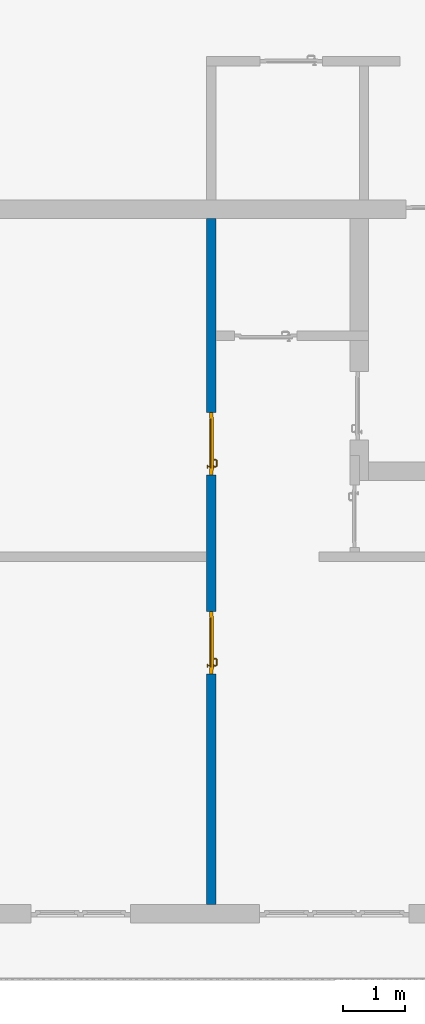
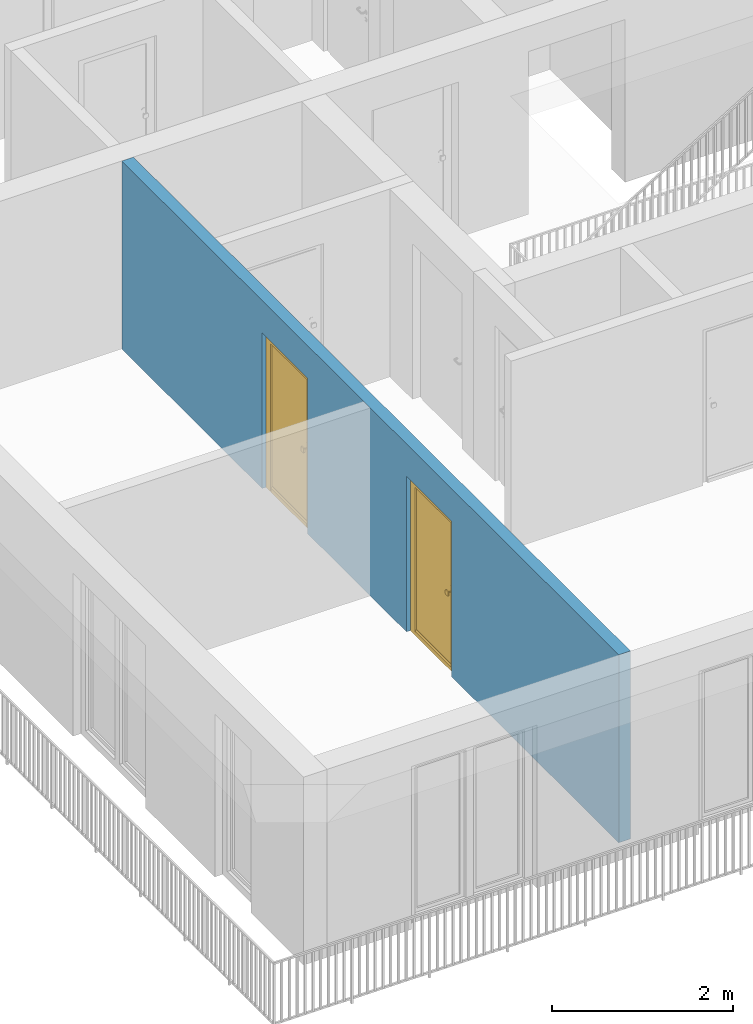
# One storey, part 8 of 54: 2 doors, 1 wall, 2 openings.
"""IFC4 building model written with IfcOpenShell, lengths in metres."""

import ifcopenshell
import ifcopenshell.guid

model = None  # the IFC model being written
_history = None  # IfcOwnerHistory: only IFC2X3 demands one
_inside = {}  # id of a spatial element -> (the spatial element, [elements in it])
_under = {}  # id of a project, library or spatial element -> (it, [spatial elements below it])
_declared = {}  # id of a project -> (the project, [libraries it declares])
_typed = {}  # id of a type object -> (the type object, [elements of that type])
_made_of = {}  # id of a material, layer set ... -> (it, [elements and type objects made of it])


def new_model(schema):
    """Start an empty IFC model of exactly this schema.

    Asked for "IFC4X3", IfcOpenShell would pick the latest addendum, in which some entities
    have other attributes; the version numbers below select the first issue.
    IFC2X3 requires an IfcOwnerHistory on every rooted entity: one is made here for all.
    """
    global model, _history
    if schema == "IFC4X3":
        model = ifcopenshell.file(schema_version=(4, 3, 0, 0))
    else:
        model = ifcopenshell.file(schema=schema)
    _inside.clear()
    _under.clear()
    _declared.clear()
    _typed.clear()
    _made_of.clear()
    _history = None
    if model.schema == "IFC2X3":
        org = make("IfcOrganization", Name="unknown")
        user = make(
            "IfcPersonAndOrganization",
            ThePerson=make("IfcPerson", FamilyName="unknown"),
            TheOrganization=org,
        )
        app = make(
            "IfcApplication",
            ApplicationDeveloper=org,
            Version="unknown",
            ApplicationFullName="unknown",
            ApplicationIdentifier="unknown",
        )
        _history = make(
            "IfcOwnerHistory",
            OwningUser=user,
            OwningApplication=app,
            ChangeAction="ADDED",
            CreationDate=0,
        )
    return model


def make(cls, **values):
    """One entity of the class cls with the attributes given. An attribute that is None is left unset."""
    return model.create_entity(
        cls, **{name: value for name, value in values.items() if value is not None}
    )


def entity(cls, *values):
    """Any entity or typed value of the class cls, its attributes in the order of the schema. None: left unset."""
    e = model.create_entity(cls)
    for i, value in enumerate(values):
        if value is not None:
            e[i] = value
    return e


def rooted(cls, **values):
    """An entity with a GlobalId (a new one), such as an element, a storey or a relation."""
    return make(cls, GlobalId=ifcopenshell.guid.new(), OwnerHistory=_history, **values)


def si_unit(unit_type, name, prefix=None):
    """IfcSIUnit, for example si_unit("LENGTHUNIT", "METRE", prefix="MILLI")."""
    return make("IfcSIUnit", UnitType=unit_type, Prefix=prefix, Name=name)


def converted_unit(unit_type, name, factor, base, dimensions=None, offset=None):
    """IfcConversionBasedUnit, such as the inch: factor (a typed value) times the base unit."""
    return make(
        "IfcConversionBasedUnit"
        if offset is None
        else "IfcConversionBasedUnitWithOffset",
        ConversionOffset=offset,
        Dimensions=None
        if dimensions is None
        else entity("IfcDimensionalExponents", *dimensions),
        UnitType=unit_type,
        Name=name,
        ConversionFactor=make(
            "IfcMeasureWithUnit", ValueComponent=factor, UnitComponent=base
        ),
    )


def derived_unit(unit_type, elements):
    """IfcDerivedUnit: a product of units, each with its exponent."""
    return make(
        "IfcDerivedUnit",
        Elements=[
            make("IfcDerivedUnitElement", Unit=unit, Exponent=power)
            for unit, power in elements
        ],
        UnitType=unit_type,
    )


def assignment(units):
    """IfcUnitAssignment: the units of a project."""
    return None if units is None else make("IfcUnitAssignment", Units=units)


def point(xyz):
    """IfcCartesianPoint."""
    return None if xyz is None else make("IfcCartesianPoint", Coordinates=xyz)


def direction(xyz):
    """IfcDirection."""
    return None if xyz is None else make("IfcDirection", DirectionRatios=xyz)


def frame(location, z_axis=None, x_axis=None):
    """IfcAxis2Placement3D, a coordinate frame: its origin and axes. An axis left out is left unset."""
    return make(
        "IfcAxis2Placement3D",
        Location=point(location),
        Axis=direction(z_axis),
        RefDirection=direction(x_axis),
    )


def origin_with_axes():
    """The frame at (0, 0, 0) with the z axis (0, 0, 1) and the x axis (1, 0, 0) written out."""
    return frame((0.0, 0.0, 0.0), z_axis=(0.0, 0.0, 1.0), x_axis=(1.0, 0.0, 0.0))


def place(relative_to, where):
    """IfcLocalPlacement: puts the frame where relative to a parent placement (None: the world)."""
    return make(
        "IfcLocalPlacement", PlacementRelTo=relative_to, RelativePlacement=where
    )


def context(
    kind, dimensions, precision=None, world=None, true_north=None, identifier=None
):
    """IfcGeometricRepresentationContext, for example the 3D "Model" context."""
    return make(
        "IfcGeometricRepresentationContext",
        ContextIdentifier=identifier,
        ContextType=kind,
        CoordinateSpaceDimension=dimensions,
        Precision=precision,
        WorldCoordinateSystem=world,
        TrueNorth=true_north,
    )


def subcontext(parent, identifier, kind, view, scale=None):
    """IfcGeometricRepresentationSubContext, for example "Body" below "Model"."""
    return make(
        "IfcGeometricRepresentationSubContext",
        ContextIdentifier=identifier,
        ContextType=kind,
        ParentContext=parent,
        TargetScale=scale,
        TargetView=view,
    )


def project(units=None, contexts=None):
    """IfcProject with its units and contexts."""
    return rooted(
        "IfcProject",
        Name="project",
        RepresentationContexts=contexts,
        UnitsInContext=assignment(units),
    )


def spatial(cls, under=None, at=None, **own):
    """A site, building, storey or space (cls), placed at a placement, below another one or the project."""
    s = rooted(cls, ObjectPlacement=at, **own)
    if under is not None:
        _under.setdefault(under.id(), (under, []))[1].append(s)
    return s


def point_list(points):
    """IfcCartesianPointList2D or 3D."""
    cls = (
        "IfcCartesianPointList2D" if len(points[0]) == 2 else "IfcCartesianPointList3D"
    )
    return make(cls, CoordList=points)


def polygons(points, faces, closed=None, point_numbers=None):
    """IfcPolygonalFaceSet: a face is its outer loop, then its inner loops; points numbered from 1."""
    made = []
    for loops in faces:
        if len(loops) == 1:
            made.append(make("IfcIndexedPolygonalFace", CoordIndex=loops[0]))
        else:
            made.append(
                make(
                    "IfcIndexedPolygonalFaceWithVoids",
                    CoordIndex=loops[0],
                    InnerCoordIndices=loops[1:],
                )
            )
    return make(
        "IfcPolygonalFaceSet",
        Coordinates=point_list(points),
        Closed=closed,
        Faces=made,
        PnIndex=point_numbers,
    )


def shape(context_of_items, identifier, shape_type, items):
    """IfcShapeRepresentation: the items that make up one representation, for example the "Body"."""
    return make(
        "IfcShapeRepresentation",
        ContextOfItems=context_of_items,
        RepresentationIdentifier=identifier,
        RepresentationType=shape_type,
        Items=items,
    )


def source(mapping_origin, context_of_items, identifier, shape_type, items):
    """IfcRepresentationMap: a shape defined once, which mapped items show again and again."""
    return make(
        "IfcRepresentationMap",
        MappingOrigin=mapping_origin,
        MappedRepresentation=shape(context_of_items, identifier, shape_type, items),
    )


def transform(
    local_origin,
    x_axis=None,
    y_axis=None,
    z_axis=None,
    scale=None,
    scale2=None,
    scale3=None,
    uniform=True,
):
    """IfcCartesianTransformationOperator3D, or its non-uniform kind. x_axis, y_axis, z_axis: its Axis1, 2, 3."""
    if uniform:
        return make(
            "IfcCartesianTransformationOperator3D",
            Axis1=direction(x_axis),
            Axis2=direction(y_axis),
            LocalOrigin=point(local_origin),
            Scale=scale,
            Axis3=direction(z_axis),
        )
    return make(
        "IfcCartesianTransformationOperator3DnonUniform",
        Axis1=direction(x_axis),
        Axis2=direction(y_axis),
        LocalOrigin=point(local_origin),
        Scale=scale,
        Axis3=direction(z_axis),
        Scale2=scale2,
        Scale3=scale3,
    )


def mapped(mapping_source, mapping_target):
    """IfcMappedItem: shows the shape of a source again, moved by a transform."""
    return make(
        "IfcMappedItem", MappingSource=mapping_source, MappingTarget=mapping_target
    )


def material(Name=None, Category=None):
    """IfcMaterial."""
    return make("IfcMaterial", Name=Name, Category=Category)


def made_of(thing, what):
    """Note that an element or type object is made of a material, layer set ...; save() writes the relation."""
    if what is not None:
        _made_of.setdefault(what.id(), (what, []))[1].append(thing)
    return thing


def type_object(cls, material=None, **own):
    """A type object (cls), such as IfcWallType, which elements share."""
    return made_of(rooted(cls, **own), material)


def element(
    cls,
    number,
    at=None,
    inside=None,
    cuts=None,
    type_object=None,
    material=None,
    context=None,
    identifier="Body",
    shape_type=None,
    held_by="IfcProductDefinitionShape",
    body=None,
    shapes=None,
    **own,
):
    """One element of the class cls, such as IfcWall. Its Tag is "e" and its number.

    at: its placement. inside: the storey or other place that contains it. cuts: it is an
    opening in that element (IfcRelVoidsElement). A single representation is given by context,
    identifier, shape_type and body (its items); several are given by shapes. held_by: the class
    of the entity that holds the representations. save() writes the other relations.
    """
    e = rooted(cls, Tag="e%d" % number, ObjectPlacement=at, **own)
    if body is not None:
        shapes = [shape(context, identifier, shape_type, body)]
    if shapes is not None:
        e.Representation = make(held_by, Representations=shapes)
    if inside is not None:
        _inside.setdefault(inside.id(), (inside, []))[1].append(e)
    if cuts is not None:
        rooted(
            "IfcRelVoidsElement", RelatingBuildingElement=cuts, RelatedOpeningElement=e
        )
    if type_object is not None:
        _typed.setdefault(type_object.id(), (type_object, []))[1].append(e)
    return made_of(e, material)


def fill(opening, filler):
    """IfcRelFillsElement: the door or window that sits in an opening."""
    return rooted(
        "IfcRelFillsElement",
        RelatingOpeningElement=opening,
        RelatedBuildingElement=filler,
    )


def aggregate(whole, parts):
    """IfcRelAggregates: a whole, such as a stair, and the parts it consists of."""
    return rooted("IfcRelAggregates", RelatingObject=whole, RelatedObjects=parts)


def save(model, path):
    """Write the relations noted so far, then the file.

    IfcRelAggregates (storeys below a building ...), IfcRelContainedInSpatialStructure (elements
    in a storey), IfcRelDefinesByType, IfcRelAssociatesMaterial and IfcRelDeclares: one each for
    every whole, place, type object, material and project.
    """
    for whole, parts in _under.values():
        aggregate(whole, parts)
    for where, things in _inside.values():
        rooted(
            "IfcRelContainedInSpatialStructure",
            RelatedElements=things,
            RelatingStructure=where,
        )
    for kind, things in _typed.values():
        rooted("IfcRelDefinesByType", RelatedObjects=things, RelatingType=kind)
    for what, things in _made_of.values():
        rooted("IfcRelAssociatesMaterial", RelatedObjects=things, RelatingMaterial=what)
    for by, libraries in _declared.values():
        rooted("IfcRelDeclares", RelatingContext=by, RelatedDefinitions=libraries)
    model.write(path)


model = new_model("IFC4")

# Units and contexts
model_context = context("Model", 3, precision=1e-05, world=origin_with_axes(), true_north=direction((0.0, 1.0)))
body_context = subcontext(model_context, "Body", "Model", "MODEL_VIEW")
ifc_project = project(units=[si_unit("LENGTHUNIT", "METRE"), si_unit("AREAUNIT", "SQUARE_METRE"), si_unit("VOLUMEUNIT", "CUBIC_METRE"), converted_unit("PLANEANGLEUNIT", "DEGREE", entity("IfcPlaneAngleMeasure", 0.0174532925199), si_unit("PLANEANGLEUNIT", "RADIAN"), dimensions=[0, 0, 0, 0, 0, 0, 0]), converted_unit("TIMEUNIT", "Year", entity("IfcTimeMeasure", 31556926.0), si_unit("TIMEUNIT", "SECOND"), dimensions=[0, 0, 1, 0, 0, 0, 0]), si_unit("MASSUNIT", "GRAM", prefix="KILO"), si_unit("THERMODYNAMICTEMPERATUREUNIT", "DEGREE_CELSIUS"), si_unit("LUMINOUSINTENSITYUNIT", "LUMEN"), si_unit("ENERGYUNIT", "JOULE", prefix="MEGA"), derived_unit("THERMALCONDUCTANCEUNIT", [(si_unit("POWERUNIT", "WATT"), 1), (si_unit("LENGTHUNIT", "METRE"), -1), (si_unit("THERMODYNAMICTEMPERATUREUNIT", "KELVIN"), -1)]), derived_unit("SPECIFICHEATCAPACITYUNIT", [(si_unit("ENERGYUNIT", "JOULE"), 1), (si_unit("MASSUNIT", "GRAM", prefix="KILO"), -1), (si_unit("THERMODYNAMICTEMPERATUREUNIT", "KELVIN"), -1)]), derived_unit("MASSDENSITYUNIT", [(si_unit("MASSUNIT", "GRAM", prefix="KILO"), 1), (si_unit("VOLUMEUNIT", "CUBIC_METRE"), -1)])], contexts=[model_context])

# Site, building, storey
site_placement = place(None, origin_with_axes())
site = spatial("IfcSite", under=ifc_project, at=site_placement, CompositionType="ELEMENT")
building_placement = place(site_placement, origin_with_axes())
building = spatial("IfcBuilding", under=site, at=building_placement, CompositionType="ELEMENT")
storey_placement = place(building_placement, frame((0.0, 0.0, 6.29), z_axis=(0.0, 0.0, 1.0), x_axis=(1.0, 0.0, 0.0)))
storey = spatial("IfcBuildingStorey", under=building, at=storey_placement, Name="2. Geschoss", CompositionType="ELEMENT", Elevation=6.29)

# Wall, openings, doors
ifc_material = material()
wall_type = type_object("IfcWallType", Name="150", PredefinedType="NOTDEFINED")
wall_placement = place(storey_placement, frame((-7.5421993804, 1.37118776896, 0.0), z_axis=(0.0, 0.0, 1.0), x_axis=(0.0, -1.0, 0.0)))
wall = element("IfcWall", 1, at=wall_placement, inside=storey, type_object=wall_type, material=ifc_material, Name="Wand-003", PredefinedType="NOTDEFINED", context=body_context, shape_type="Tessellation", body=[
    polygons([(7.3, 0.15, 0.0), (7.3, 0.15, 2.1), (6.3, 0.15, 2.1), (6.3, 0.15, 0.0), (4.1078818937, 0.15, 0.0), (4.1078818937, 0.15, 2.1), (3.1078818937, 0.15, 2.1), (3.1078818937, 0.15, 0.0), (0.0, 0.15, 0.0), (0.0, 0.15, 2.54), (11.0, 0.15, 2.54), (11.0, 0.15, 0.0), (7.3, 0.05, 0.0), (7.3, 0.0, 0.0), (7.3, 0.0, 2.1), (6.3, 0.0, 2.1), (6.3, 0.05, 0.0), (6.3, 0.0, 0.0), (4.1078818937, 0.0, 0.0), (4.1078818937, 0.0, 2.1), (3.1078818937, 0.0, 2.1), (3.1078818937, 0.0, 0.0), (0.0, 0.0, 0.0), (0.0, 0.0, 2.54), (11.0, 0.0, 2.54), (11.0, 0.0, 0.0)], [[[1, 2, 3, 4, 5, 6, 7, 8, 9, 10, 11, 12]], [[2, 1, 13, 14, 15]], [[3, 2, 15, 16]], [[17, 4, 3, 16, 18]], [[4, 17, 18, 19, 5]], [[19, 20, 6, 5]], [[20, 21, 7, 6]], [[21, 22, 8, 7]], [[23, 9, 8, 22]], [[23, 24, 10, 9]], [[25, 11, 10, 24]], [[12, 11, 25, 26]], [[13, 1, 12, 26, 14]], [[19, 18, 16, 15, 14, 26, 25, 24, 23, 22, 21, 20]]], closed=True),
])
opening_1_placement = place(wall_placement, frame((3.6078818937, 0.0, 0.0), z_axis=(0.0, 0.0, 1.0), x_axis=(1.0, 0.0, 0.0)))
opening_1 = element("IfcOpeningElement", 2, at=opening_1_placement, cuts=wall, context=body_context, identifier="Reference", shape_type="Tessellation", body=[
    polygons([(0.5, 0.05, 0.0), (0.5, 0.05, 2.1), (0.5, -0.001, 2.1), (0.5, -0.001, 0.0), (0.5, 0.151, 0.0), (0.5, 0.151, 2.1), (-0.5, 0.05, 2.1), (-0.5, -0.001, 2.1), (-0.5, 0.151, 2.1), (-0.5, -0.001, 0.0), (-0.5, 0.05, 0.0), (-0.5, 0.151, 0.0)], [[[1, 2, 3, 4]], [[2, 1, 5, 6]], [[7, 8, 3, 2, 6, 9]], [[8, 10, 4, 3]], [[1, 4, 10, 11, 12, 5]], [[6, 5, 12, 9]], [[7, 11, 10, 8]], [[11, 7, 9, 12]]], closed=True),
])
opening_2_placement = place(wall_placement, frame((6.8, 0.0, 0.0), z_axis=(0.0, 0.0, 1.0), x_axis=(1.0, 0.0, 0.0)))
opening_2 = element("IfcOpeningElement", 3, at=opening_2_placement, cuts=wall, context=body_context, identifier="Reference", shape_type="Tessellation", body=[
    polygons([(0.5, 0.05, 0.0), (0.5, 0.05, 2.1), (0.5, -0.001, 2.1), (0.5, -0.001, 0.0), (0.5, 0.151, 0.0), (0.5, 0.151, 2.1), (-0.5, 0.05, 2.1), (-0.5, -0.001, 2.1), (-0.5, 0.151, 2.1), (-0.5, -0.001, 0.0), (-0.5, 0.05, 0.0), (-0.5, 0.151, 0.0)], [[[1, 2, 3, 4]], [[2, 1, 5, 6]], [[7, 8, 3, 2, 6, 9]], [[8, 10, 4, 3]], [[1, 4, 10, 11, 12, 5]], [[6, 5, 12, 9]], [[7, 11, 10, 8]], [[11, 7, 9, 12]]], closed=True),
])
door_type = type_object("IfcDoorType", Name="Eingang 01 1-Fl 26", OperationType="SINGLE_SWING_LEFT", PredefinedType="DOOR")
shared_shape = source(origin_with_axes(), body_context, "Body", "Tessellation", [
    polygons([(-0.5, -0.05, 0.0), (-0.5, -0.05, 2.1), (-0.5, -0.03, 2.1), (-0.5, -0.03, 0.0), (-0.4, -0.05, 0.0), (-0.4, -0.05, 2.0), (-0.1301, -0.05, 2.0), (-0.0001, -0.05, 2.0), (0.4, -0.05, 2.0), (0.4, -0.05, 0.0), (0.5, -0.05, 0.0), (0.5, -0.05, 2.1), (0.5, -0.03, 2.1), (0.5, -0.03, 0.0), (0.4, -0.03, 0.0), (0.4, -0.03, 2.0), (-0.0001, -0.03, 2.0), (-0.1301, -0.03, 2.0), (-0.4, -0.03, 2.0), (-0.4, -0.03, 0.0)], [[[1, 2, 3, 4]], [[1, 5, 6, 7, 8, 9, 10, 11, 12, 2]], [[2, 12, 13, 3]], [[4, 3, 13, 14, 15, 16, 17, 18, 19, 20]], [[5, 1, 4, 20]], [[6, 5, 20, 19]], [[7, 6, 19, 18]], [[8, 7, 18, 17]], [[9, 8, 17, 16]], [[10, 9, 16, 15]], [[11, 10, 15, 14]], [[12, 11, 14, 13]]], closed=True),
    polygons([(-0.5, -0.03, 0.0), (-0.5, -0.03, 2.1), (-0.5, 0.0, 2.1), (-0.5, 0.0, 0.0), (-0.43, -0.03, 0.0), (-0.43, -0.03, 2.03), (-0.1001, -0.03, 2.03), (-0.0301, -0.03, 2.03), (0.43, -0.03, 2.03), (0.43, -0.03, 0.0), (0.5, -0.03, 0.0), (0.5, -0.03, 2.1), (0.5, 0.0, 2.1), (0.5, 0.0, 0.0), (0.43, 0.0, 0.0), (0.43, 0.0, 2.03), (-0.0301, 0.0, 2.03), (-0.1001, 0.0, 2.03), (-0.43, 0.0, 2.03), (-0.43, 0.0, 0.0)], [[[1, 2, 3, 4]], [[1, 5, 6, 7, 8, 9, 10, 11, 12, 2]], [[2, 12, 13, 3]], [[4, 3, 13, 14, 15, 16, 17, 18, 19, 20]], [[5, 1, 4, 20]], [[6, 5, 20, 19]], [[7, 6, 19, 18]], [[8, 7, 18, 17]], [[9, 8, 17, 16]], [[10, 9, 16, 15]], [[11, 10, 15, 14]], [[12, 11, 14, 13]]], closed=True),
    polygons([(-0.43, 0.01, 0.0), (-0.43, 0.01, 2.03), (0.43, 0.01, 2.03), (0.43, 0.01, 0.0), (-0.43, -0.03, 0.0), (-0.43, -0.03, 2.03), (0.43, -0.03, 2.03), (0.43, -0.03, 0.0)], [[[1, 2, 3, 4]], [[1, 5, 6, 2]], [[2, 6, 7, 3]], [[3, 7, 8, 4]], [[4, 8, 5, 1]], [[8, 7, 6, 5]]], closed=True),
    polygons([(-0.395, -0.05, 0.0), (0.395, -0.05, 0.0), (0.395, -0.05, 0.05), (-0.395, -0.05, 0.05), (-0.395, -0.03, 0.0), (0.395, -0.03, 0.0), (0.395, -0.03, 0.07), (0.395, -0.035, 0.07), (-0.395, -0.035, 0.07), (-0.395, -0.03, 0.07)], [[[1, 2, 3, 4]], [[5, 6, 2, 1]], [[2, 6, 7, 8, 3]], [[4, 3, 8, 9]], [[1, 4, 9, 10, 5]], [[10, 7, 6, 5]], [[9, 8, 7, 10]]], closed=True),
    polygons([(0.3835, 0.02, 1.0733826859), (0.37, 0.02, 1.077), (0.37, 0.0199, 1.077), (0.3835, 0.0199, 1.0733826859), (0.393382685902, 0.02, 1.0635), (0.397, 0.02, 1.05), (0.393382685902, 0.02, 1.0365), (0.3835, 0.02, 1.0266173141), (0.37, 0.02, 1.023), (0.3565, 0.02, 1.0266173141), (0.346617314098, 0.02, 1.0365), (0.343, 0.02, 1.05), (0.346617314098, 0.02, 1.0635), (0.3565, 0.02, 1.0733826859), (0.3565, 0.0199, 1.0733826859), (0.37, 0.0101, 1.077), (0.3835, 0.0101, 1.0733826859), (0.393382685902, 0.0199, 1.0635), (0.397, 0.0199, 1.05), (0.393382685902, 0.0199, 1.0365), (0.3835, 0.0199, 1.0266173141), (0.37, 0.0199, 1.023), (0.3565, 0.0199, 1.0266173141), (0.346617314098, 0.0199, 1.0365), (0.343, 0.0199, 1.05), (0.346617314098, 0.0199, 1.0635), (0.3565, 0.0101, 1.0733826859), (0.37, 0.01, 1.077), (0.3835, 0.01, 1.0733826859), (0.393382685902, 0.0101, 1.0635), (0.397, 0.0101, 1.05), (0.393382685902, 0.0101, 1.0365), (0.3835, 0.0101, 1.0266173141), (0.37, 0.0101, 1.023), (0.3565, 0.0101, 1.0266173141), (0.346617314098, 0.0101, 1.0365), (0.343, 0.0101, 1.05), (0.346617314098, 0.0101, 1.0635), (0.3565, 0.01, 1.0733826859), (0.346617314098, 0.01, 1.0635), (0.343, 0.01, 1.05), (0.346617314098, 0.01, 1.0365), (0.3565, 0.01, 1.0266173141), (0.37, 0.01, 1.023), (0.3835, 0.01, 1.0266173141), (0.393382685902, 0.01, 1.0365), (0.397, 0.01, 1.05), (0.393382685902, 0.01, 1.0635)], [[[1, 2, 3, 4]], [[2, 1, 5, 6, 7, 8, 9, 10, 11, 12, 13, 14]], [[2, 14, 15, 3]], [[4, 3, 16, 17]], [[5, 1, 4, 18]], [[6, 5, 18, 19]], [[7, 6, 19, 20]], [[8, 7, 20, 21]], [[9, 8, 21, 22]], [[10, 9, 22, 23]], [[11, 10, 23, 24]], [[12, 11, 24, 25]], [[13, 12, 25, 26]], [[14, 13, 26, 15]], [[3, 15, 27, 16]], [[17, 16, 28, 29]], [[18, 4, 17, 30]], [[19, 18, 30, 31]], [[20, 19, 31, 32]], [[21, 20, 32, 33]], [[22, 21, 33, 34]], [[23, 22, 34, 35]], [[24, 23, 35, 36]], [[25, 24, 36, 37]], [[26, 25, 37, 38]], [[15, 26, 38, 27]], [[16, 27, 39, 28]], [[28, 39, 40, 41, 42, 43, 44, 45, 46, 47, 48, 29]], [[30, 17, 29, 48]], [[31, 30, 48, 47]], [[32, 31, 47, 46]], [[33, 32, 46, 45]], [[34, 33, 45, 44]], [[35, 34, 44, 43]], [[36, 35, 43, 42]], [[37, 36, 42, 41]], [[38, 37, 41, 40]], [[27, 38, 40, 39]]], closed=True),
    polygons([(0.362532169224, 0.019, 0.959692280177), (0.363279754556, 0.019, 0.961639806549), (0.35705, 0.019, 0.972430057958), (0.347569942042, 0.019, 0.96295), (0.365, 0.019, 0.952886751346), (0.365, 0.019, 0.9544), (0.362532169224, 0.02, 0.959692280177), (0.363279754556, 0.02, 0.961639806549), (0.364624817685, 0.02, 0.965143815798), (0.364624817685, 0.019, 0.965143815798), (0.37, 0.019, 0.967425445323), (0.37, 0.019, 0.9759), (0.357, 0.019, 0.972516660498), (0.347483339502, 0.019, 0.963), (0.365, 0.019, 0.95), (0.3441, 0.019, 0.95), (0.365, 0.019, 0.947113248654), (0.365, 0.019, 0.941339745962), (0.365, 0.019, 0.9375), (0.365, 0.02, 0.9375), (0.365, 0.02, 0.941339745962), (0.365, 0.02, 0.947113248654), (0.365, 0.02, 0.95), (0.365, 0.02, 0.952886751346), (0.365, 0.02, 0.9544), (0.346703916638, 0.02, 0.96345), (0.35655, 0.02, 0.973296083362), (0.37, 0.02, 0.9769), (0.37, 0.02, 0.967425445323), (0.375375182315, 0.019, 0.965143815798), (0.376720245444, 0.019, 0.961639806549), (0.38295, 0.019, 0.972430057958), (0.37, 0.019, 0.976), (0.357, 0.0189, 0.972516660498), (0.347483339502, 0.0189, 0.963), (0.344, 0.019, 0.95), (0.347569942042, 0.019, 0.93705), (0.35705, 0.019, 0.927569942042), (0.37, 0.019, 0.9241), (0.37, 0.019, 0.9325), (0.366464466094, 0.019, 0.933964466094), (0.366464466094, 0.02, 0.933964466094), (0.37, 0.02, 0.9231), (0.35655, 0.02, 0.926703916638), (0.37, 0.02, 0.9325), (0.346703916638, 0.02, 0.93655), (0.3431, 0.02, 0.95), (0.346617314098, 0.02, 0.9635), (0.3565, 0.02, 0.973382685902), (0.37, 0.02, 0.977), (0.375375182315, 0.02, 0.965143815798), (0.38345, 0.02, 0.973296083362), (0.376720245444, 0.02, 0.961639806549), (0.377467830776, 0.02, 0.959692280177), (0.377467830776, 0.019, 0.959692280177), (0.375, 0.019, 0.9544), (0.375, 0.019, 0.952886751346), (0.392430057958, 0.019, 0.96295), (0.383, 0.019, 0.972516660498), (0.37, 0.0189, 0.976), (0.357, 0.0101, 0.972516660498), (0.347483339502, 0.0101, 0.963), (0.344, 0.0189, 0.95), (0.347483339502, 0.019, 0.937), (0.357, 0.019, 0.927483339502), (0.37, 0.019, 0.924), (0.38295, 0.019, 0.927569942042), (0.375, 0.019, 0.941339745962), (0.375, 0.019, 0.9375), (0.373535533906, 0.019, 0.933964466094), (0.37, 0.02, 0.923), (0.3565, 0.02, 0.926617314098), (0.38345, 0.02, 0.926703916638), (0.373535533906, 0.02, 0.933964466094), (0.375, 0.02, 0.9375), (0.375, 0.02, 0.941339745962), (0.346617314098, 0.02, 0.9365), (0.343, 0.02, 0.95), (0.346617314098, 0.0199, 0.9635), (0.3565, 0.0199, 0.973382685902), (0.37, 0.0199, 0.977), (0.3835, 0.02, 0.973382685902), (0.393296083362, 0.02, 0.96345), (0.375, 0.02, 0.952886751346), (0.375, 0.02, 0.9544), (0.375, 0.02, 0.95), (0.375, 0.02, 0.947113248654), (0.375, 0.019, 0.947113248654), (0.375, 0.019, 0.95), (0.3959, 0.019, 0.95), (0.392516660498, 0.019, 0.963), (0.383, 0.0189, 0.972516660498), (0.37, 0.0101, 0.976), (0.357, 0.01, 0.972516660498), (0.347483339502, 0.01, 0.963), (0.344, 0.0101, 0.95), (0.347483339502, 0.0189, 0.937), (0.357, 0.0189, 0.927483339502), (0.37, 0.0189, 0.924), (0.383, 0.019, 0.927483339502), (0.392430057958, 0.019, 0.93705), (0.37, 0.0199, 0.923), (0.3565, 0.0199, 0.926617314098), (0.3835, 0.02, 0.926617314098), (0.393296083362, 0.02, 0.93655), (0.346617314098, 0.0199, 0.9365), (0.343, 0.0199, 0.95), (0.346617314098, 0.0101, 0.9635), (0.3565, 0.0101, 0.973382685902), (0.37, 0.0101, 0.977), (0.3835, 0.0199, 0.973382685902), (0.393382685902, 0.02, 0.9635), (0.3969, 0.02, 0.95), (0.396, 0.019, 0.95), (0.392516660498, 0.0189, 0.963), (0.383, 0.0101, 0.972516660498), (0.37, 0.01, 0.976), (0.35695, 0.01, 0.972603263039), (0.347396736961, 0.01, 0.96305), (0.344, 0.01, 0.95), (0.347483339502, 0.0101, 0.937), (0.357, 0.0101, 0.927483339502), (0.37, 0.0101, 0.924), (0.383, 0.0189, 0.927483339502), (0.392516660498, 0.019, 0.937), (0.37, 0.0101, 0.923), (0.3565, 0.0101, 0.926617314098), (0.3835, 0.0199, 0.926617314098), (0.393382685902, 0.02, 0.9365), (0.346617314098, 0.0101, 0.9365), (0.343, 0.0101, 0.95), (0.346617314098, 0.01, 0.9635), (0.3565, 0.01, 0.973382685902), (0.37, 0.01, 0.977), (0.3835, 0.0101, 0.973382685902), (0.393382685902, 0.0199, 0.9635), (0.397, 0.02, 0.95), (0.396, 0.0189, 0.95), (0.392516660498, 0.0101, 0.963), (0.383, 0.01, 0.972516660498), (0.37, 0.01, 0.9761), (0.35655, 0.01, 0.973296083362), (0.346703916638, 0.01, 0.96345), (0.3439, 0.01, 0.95), (0.347483339502, 0.01, 0.937), (0.357, 0.01, 0.927483339502), (0.37, 0.01, 0.924), (0.383, 0.0101, 0.927483339502), (0.392516660498, 0.0189, 0.937), (0.37, 0.01, 0.923), (0.3565, 0.01, 0.926617314098), (0.3835, 0.0101, 0.926617314098), (0.393382685902, 0.0199, 0.9365), (0.346617314098, 0.01, 0.9365), (0.343, 0.01, 0.95), (0.37, 0.01, 0.9769), (0.3835, 0.01, 0.973382685902), (0.393382685902, 0.0101, 0.9635), (0.397, 0.0199, 0.95), (0.396, 0.0101, 0.95), (0.392516660498, 0.01, 0.963), (0.38305, 0.01, 0.972603263039), (0.3431, 0.01, 0.95), (0.347396736961, 0.01, 0.93695), (0.35695, 0.01, 0.927396736961), (0.37, 0.01, 0.9239), (0.383, 0.01, 0.927483339502), (0.392516660498, 0.0101, 0.937), (0.37, 0.01, 0.9231), (0.35655, 0.01, 0.926703916638), (0.3835, 0.01, 0.926617314098), (0.393382685902, 0.0101, 0.9365), (0.346703916638, 0.01, 0.93655), (0.38345, 0.01, 0.973296083362), (0.393382685902, 0.01, 0.9635), (0.397, 0.0101, 0.95), (0.396, 0.01, 0.95), (0.392603263039, 0.01, 0.96305), (0.38305, 0.01, 0.927396736961), (0.392516660498, 0.01, 0.937), (0.38345, 0.01, 0.926703916638), (0.393382685902, 0.01, 0.9365), (0.393296083362, 0.01, 0.96345), (0.397, 0.01, 0.95), (0.3961, 0.01, 0.95), (0.392603263039, 0.01, 0.93695), (0.393296083362, 0.01, 0.93655), (0.3969, 0.01, 0.95)], [[[1, 2, 3, 4, 5, 6]], [[1, 7, 8, 9, 10, 2]], [[10, 11, 12, 3, 2]], [[4, 3, 13, 14]], [[15, 5, 4, 16]], [[6, 5, 15, 17, 18, 19, 20, 21, 22, 23, 24, 25]], [[6, 25, 7, 1]], [[7, 25, 24, 26, 27, 8]], [[9, 8, 27, 28, 29]], [[10, 9, 29, 11]], [[30, 31, 32, 12, 11]], [[3, 12, 33, 13]], [[14, 13, 34, 35]], [[16, 4, 14, 36]], [[17, 15, 16, 37]], [[18, 17, 37, 38]], [[38, 39, 40, 41, 19, 18]], [[19, 41, 42, 20]], [[43, 44, 21, 20, 42, 45]], [[22, 21, 44, 46]], [[23, 22, 46, 47]], [[24, 23, 47, 26]], [[48, 49, 27, 26]], [[49, 50, 28, 27]], [[51, 29, 28, 52, 53]], [[11, 29, 51, 30]], [[30, 51, 53, 54, 55, 31]], [[55, 56, 57, 58, 32, 31]], [[12, 32, 59, 33]], [[13, 33, 60, 34]], [[35, 34, 61, 62]], [[36, 14, 35, 63]], [[37, 16, 36, 64]], [[38, 37, 64, 65]], [[39, 38, 65, 66]], [[39, 67, 68, 69, 70, 40]], [[41, 40, 45, 42]], [[71, 72, 44, 43]], [[73, 43, 45, 74, 75, 76]], [[72, 77, 46, 44]], [[77, 78, 47, 46]], [[78, 48, 26, 47]], [[79, 80, 49, 48]], [[80, 81, 50, 49]], [[50, 82, 52, 28]], [[54, 53, 52, 83, 84, 85]], [[55, 54, 85, 56]], [[85, 84, 86, 87, 76, 75, 69, 68, 88, 89, 57, 56]], [[57, 89, 90, 58]], [[32, 58, 91, 59]], [[33, 59, 92, 60]], [[34, 60, 93, 61]], [[62, 61, 94, 95]], [[63, 35, 62, 96]], [[64, 36, 63, 97]], [[65, 64, 97, 98]], [[66, 65, 98, 99]], [[67, 39, 66, 100]], [[88, 68, 67, 101]], [[70, 69, 75, 74]], [[40, 70, 74, 45]], [[102, 103, 72, 71]], [[104, 71, 43, 73]], [[76, 87, 105, 73]], [[103, 106, 77, 72]], [[106, 107, 78, 77]], [[107, 79, 48, 78]], [[108, 109, 80, 79]], [[109, 110, 81, 80]], [[81, 111, 82, 50]], [[82, 112, 83, 52]], [[86, 84, 83, 113]], [[87, 86, 113, 105]], [[89, 88, 101, 90]], [[58, 90, 114, 91]], [[59, 91, 115, 92]], [[60, 92, 116, 93]], [[61, 93, 117, 94]], [[95, 94, 118, 119]], [[96, 62, 95, 120]], [[97, 63, 96, 121]], [[98, 97, 121, 122]], [[99, 98, 122, 123]], [[100, 66, 99, 124]], [[101, 67, 100, 125]], [[126, 127, 103, 102]], [[128, 102, 71, 104]], [[129, 104, 73, 105]], [[127, 130, 106, 103]], [[130, 131, 107, 106]], [[131, 108, 79, 107]], [[132, 133, 109, 108]], [[133, 134, 110, 109]], [[110, 135, 111, 81]], [[111, 136, 112, 82]], [[112, 137, 113, 83]], [[137, 129, 105, 113]], [[90, 101, 125, 114]], [[91, 114, 138, 115]], [[92, 115, 139, 116]], [[93, 116, 140, 117]], [[94, 117, 141, 118]], [[119, 118, 142, 143]], [[120, 95, 119, 144]], [[121, 96, 120, 145]], [[122, 121, 145, 146]], [[123, 122, 146, 147]], [[124, 99, 123, 148]], [[125, 100, 124, 149]], [[150, 151, 127, 126]], [[152, 126, 102, 128]], [[153, 128, 104, 129]], [[151, 154, 130, 127]], [[154, 155, 131, 130]], [[155, 132, 108, 131]], [[143, 142, 133, 132]], [[142, 156, 134, 133]], [[134, 157, 135, 110]], [[135, 158, 136, 111]], [[136, 159, 137, 112]], [[159, 153, 129, 137]], [[114, 125, 149, 138]], [[115, 138, 160, 139]], [[116, 139, 161, 140]], [[117, 140, 162, 141]], [[118, 141, 156, 142]], [[144, 119, 143, 163]], [[145, 120, 144, 164]], [[146, 145, 164, 165]], [[147, 146, 165, 166]], [[148, 123, 147, 167]], [[149, 124, 148, 168]], [[169, 170, 151, 150]], [[171, 150, 126, 152]], [[172, 152, 128, 153]], [[170, 173, 154, 151]], [[173, 163, 155, 154]], [[163, 143, 132, 155]], [[156, 174, 157, 134]], [[157, 175, 158, 135]], [[158, 176, 159, 136]], [[176, 172, 153, 159]], [[138, 149, 168, 160]], [[139, 160, 177, 161]], [[140, 161, 178, 162]], [[141, 162, 174, 156]], [[164, 144, 163, 173]], [[165, 164, 173, 170]], [[166, 165, 170, 169]], [[167, 147, 166, 179]], [[168, 148, 167, 180]], [[181, 169, 150, 171]], [[182, 171, 152, 172]], [[174, 183, 175, 157]], [[175, 184, 176, 158]], [[184, 182, 172, 176]], [[160, 168, 180, 177]], [[161, 177, 185, 178]], [[162, 178, 183, 174]], [[179, 166, 169, 181]], [[180, 167, 179, 186]], [[187, 181, 171, 182]], [[183, 188, 184, 175]], [[188, 187, 182, 184]], [[177, 180, 186, 185]], [[178, 185, 188, 183]], [[186, 179, 181, 187]], [[185, 186, 187, 188]]], closed=True),
    polygons([(0.38, 0.02, 1.05), (0.377071067812, 0.02, 1.04292893219), (0.377071067812, 0.050696439392, 1.04292893219), (0.38, 0.0509849140336, 1.05), (0.37, 0.02, 1.04), (0.37, 0.05, 1.04), (0.375518993221, 0.0584992452783, 1.04292893219), (0.378277987014, 0.0596420579258, 1.05), (0.377071067812, 0.02, 1.05707106781), (0.377071067812, 0.050696439392, 1.05707106781), (0.362928932188, 0.02, 1.04292893219), (0.362928932188, 0.049303560608, 1.04292893219), (0.368858192988, 0.0557402514855, 1.04), (0.370704557509, 0.0657045575088, 1.04292893219), (0.372816199938, 0.0678161999379, 1.05), (0.375518993221, 0.0584992452783, 1.05707106781), (0.37, 0.02, 1.06), (0.37, 0.05, 1.06), (0.36, 0.02, 1.05), (0.36, 0.0490150859664, 1.05), (0.362197392755, 0.0529812576926, 1.04292893219), (0.365606601718, 0.0606066017178, 1.04), (0.363499245278, 0.0705189932208, 1.04292893219), (0.364642057926, 0.0732779870137, 1.05), (0.370704557509, 0.0657045575088, 1.05707106781), (0.368858192988, 0.0557402514855, 1.06), (0.362928932188, 0.02, 1.05707106781), (0.362928932188, 0.049303560608, 1.05707106781), (0.359438398962, 0.0518384450452, 1.05), (0.360508645927, 0.0555086459268, 1.04292893219), (0.360740251485, 0.0638581929877, 1.04), (0.355696439392, 0.0720710678119, 1.04292893219), (0.355984914034, 0.075, 1.05), (0.363499245278, 0.0705189932208, 1.05707106781), (0.365606601718, 0.0606066017178, 1.06), (0.362197392755, 0.0529812576926, 1.05707106781), (0.358397003498, 0.0533970034977, 1.05), (0.357981257693, 0.0571973927545, 1.04292893219), (0.355, 0.065, 1.04), (0.274303560608, 0.0720710678119, 1.04292893219), (0.274015085966, 0.075, 1.05), (0.355696439392, 0.0720710678119, 1.05707106781), (0.360740251485, 0.0638581929877, 1.06), (0.360508645927, 0.0555086459268, 1.05707106781), (0.356838445045, 0.0544383989617, 1.05), (0.354303560608, 0.0579289321881, 1.04292893219), (0.275, 0.065, 1.04), (0.266500754722, 0.0705189932208, 1.04292893219), (0.265357942074, 0.0732779870137, 1.05), (0.274303560608, 0.0720710678119, 1.05707106781), (0.355, 0.065, 1.06), (0.357981257693, 0.0571973927545, 1.05707106781), (0.354015085966, 0.055, 1.05), (0.275696439392, 0.0579289321881, 1.04292893219), (0.269259748515, 0.0638581929877, 1.04), (0.259295442491, 0.0657045575088, 1.04292893219), (0.257183800062, 0.0678161999379, 1.05), (0.266500754722, 0.0705189932208, 1.05707106781), (0.275, 0.065, 1.06), (0.354303560608, 0.0579289321881, 1.05707106781), (0.275984914034, 0.055, 1.05), (0.272018742307, 0.0571973927545, 1.04292893219), (0.264393398282, 0.0606066017178, 1.04), (0.254481006779, 0.0584992452783, 1.04292893219), (0.251722012986, 0.0596420579258, 1.05), (0.259295442491, 0.0657045575088, 1.05707106781), (0.269259748515, 0.0638581929877, 1.06), (0.275696439392, 0.0579289321881, 1.05707106781), (0.273161554955, 0.0544383989617, 1.05), (0.269491354073, 0.0555086459268, 1.04292893219), (0.261141807012, 0.0557402514855, 1.04), (0.252928932188, 0.050696439392, 1.04292893219), (0.25, 0.0509849140336, 1.05), (0.254481006779, 0.0584992452783, 1.05707106781), (0.264393398282, 0.0606066017178, 1.06), (0.272018742307, 0.0571973927545, 1.05707106781), (0.271602996502, 0.0533970034977, 1.05), (0.267802607245, 0.0529812576926, 1.04292893219), (0.26, 0.05, 1.04), (0.252928932188, 0.02, 1.04292893219), (0.25, 0.02, 1.05), (0.252928932188, 0.050696439392, 1.05707106781), (0.261141807012, 0.0557402514855, 1.06), (0.269491354073, 0.0555086459268, 1.05707106781), (0.270561601038, 0.0518384450452, 1.05), (0.267071067812, 0.049303560608, 1.04292893219), (0.26, 0.02, 1.04), (0.267071067812, 0.02, 1.04292893219), (0.27, 0.02, 1.05), (0.267071067812, 0.02, 1.05707106781), (0.26, 0.02, 1.06), (0.252928932188, 0.02, 1.05707106781), (0.26, 0.05, 1.06), (0.267802607245, 0.0529812576926, 1.05707106781), (0.27, 0.0490150859664, 1.05), (0.267071067812, 0.049303560608, 1.05707106781)], [[[1, 2, 3, 4]], [[2, 5, 6, 3]], [[4, 3, 7, 8]], [[9, 1, 4, 10]], [[5, 11, 12, 6]], [[3, 6, 13, 7]], [[8, 7, 14, 15]], [[10, 4, 8, 16]], [[17, 9, 10, 18]], [[11, 19, 20, 12]], [[6, 12, 21, 13]], [[7, 13, 22, 14]], [[15, 14, 23, 24]], [[16, 8, 15, 25]], [[18, 10, 16, 26]], [[27, 17, 18, 28]], [[19, 27, 28, 20]], [[12, 20, 29, 21]], [[13, 21, 30, 22]], [[14, 22, 31, 23]], [[24, 23, 32, 33]], [[25, 15, 24, 34]], [[26, 16, 25, 35]], [[28, 18, 26, 36]], [[20, 28, 36, 29]], [[21, 29, 37, 30]], [[22, 30, 38, 31]], [[23, 31, 39, 32]], [[33, 32, 40, 41]], [[34, 24, 33, 42]], [[35, 25, 34, 43]], [[36, 26, 35, 44]], [[29, 36, 44, 37]], [[30, 37, 45, 38]], [[31, 38, 46, 39]], [[32, 39, 47, 40]], [[41, 40, 48, 49]], [[42, 33, 41, 50]], [[43, 34, 42, 51]], [[44, 35, 43, 52]], [[37, 44, 52, 45]], [[38, 45, 53, 46]], [[39, 46, 54, 47]], [[40, 47, 55, 48]], [[49, 48, 56, 57]], [[50, 41, 49, 58]], [[51, 42, 50, 59]], [[52, 43, 51, 60]], [[45, 52, 60, 53]], [[46, 53, 61, 54]], [[47, 54, 62, 55]], [[48, 55, 63, 56]], [[57, 56, 64, 65]], [[58, 49, 57, 66]], [[59, 50, 58, 67]], [[60, 51, 59, 68]], [[53, 60, 68, 61]], [[54, 61, 69, 62]], [[55, 62, 70, 63]], [[56, 63, 71, 64]], [[65, 64, 72, 73]], [[66, 57, 65, 74]], [[67, 58, 66, 75]], [[68, 59, 67, 76]], [[61, 68, 76, 69]], [[62, 69, 77, 70]], [[63, 70, 78, 71]], [[64, 71, 79, 72]], [[73, 72, 80, 81]], [[74, 65, 73, 82]], [[75, 66, 74, 83]], [[76, 67, 75, 84]], [[69, 76, 84, 77]], [[70, 77, 85, 78]], [[71, 78, 86, 79]], [[72, 79, 87, 80]], [[81, 80, 87, 88, 89, 90, 91, 92]], [[82, 73, 81, 92]], [[83, 74, 82, 93]], [[84, 75, 83, 94]], [[77, 84, 94, 85]], [[78, 85, 95, 86]], [[79, 86, 88, 87]], [[86, 95, 89, 88]], [[95, 96, 90, 89]], [[96, 93, 91, 90]], [[93, 82, 92, 91]], [[94, 83, 93, 96]], [[85, 94, 96, 95]]], closed=False),
    polygons([(0.364696699141, -0.035, 1.04469669914), (0.3625, -0.035, 1.05), (0.364696699141, -0.035, 1.05530330086), (0.37, -0.035, 1.0575), (0.375303300859, -0.035, 1.05530330086), (0.3775, -0.035, 1.05), (0.375303300859, -0.035, 1.04469669914), (0.37, -0.035, 1.0425), (0.364696699141, -0.075, 1.04469669914), (0.3625, -0.075, 1.05), (0.364696699141, -0.075, 1.05530330086), (0.37, -0.075, 1.0575), (0.375303300859, -0.075, 1.05530330086), (0.3775, -0.075, 1.05), (0.375303300859, -0.075, 1.04469669914), (0.37, -0.075, 1.0425)], [[[1, 2, 3, 4, 5, 6, 7, 8]], [[1, 9, 10, 2]], [[2, 10, 11, 3]], [[3, 11, 12, 4]], [[4, 12, 13, 5]], [[5, 13, 14, 6]], [[6, 14, 15, 7]], [[7, 15, 16, 8]], [[8, 16, 9, 1]], [[9, 16, 15, 14, 13, 12, 11, 10]]], closed=True),
    polygons([(0.395, -0.03, 0.975), (0.395, -0.035, 0.975), (0.393096988313, -0.035, 0.965432914191), (0.393096988313, -0.03, 0.965432914191), (0.395, -0.03, 1.1), (0.395, -0.035, 1.1), (0.393096988313, -0.035, 1.10956708581), (0.38767766953, -0.035, 1.11767766953), (0.379567085809, -0.035, 1.12309698831), (0.37, -0.035, 1.125), (0.360432914191, -0.035, 1.12309698831), (0.35232233047, -0.035, 1.11767766953), (0.346903011687, -0.035, 1.10956708581), (0.345, -0.035, 1.1), (0.345, -0.035, 0.975), (0.346903011687, -0.035, 0.965432914191), (0.35232233047, -0.035, 0.95732233047), (0.360432914191, -0.035, 0.951903011687), (0.37, -0.035, 0.95), (0.379567085809, -0.035, 0.951903011687), (0.38767766953, -0.035, 0.95732233047), (0.38767766953, -0.03, 0.95732233047), (0.379567085809, -0.03, 0.951903011687), (0.37, -0.03, 0.95), (0.360432914191, -0.03, 0.951903011687), (0.35232233047, -0.03, 0.95732233047), (0.346903011687, -0.03, 0.965432914191), (0.345, -0.03, 0.975), (0.345, -0.03, 1.1), (0.346903011687, -0.03, 1.10956708581), (0.35232233047, -0.03, 1.11767766953), (0.360432914191, -0.03, 1.12309698831), (0.37, -0.03, 1.125), (0.379567085809, -0.03, 1.12309698831), (0.38767766953, -0.03, 1.11767766953), (0.393096988313, -0.03, 1.10956708581)], [[[1, 2, 3, 4]], [[5, 6, 2, 1]], [[2, 6, 7, 8, 9, 10, 11, 12, 13, 14, 15, 16, 17, 18, 19, 20, 21, 3]], [[4, 3, 21, 22]], [[1, 4, 22, 23, 24, 25, 26, 27, 28, 29, 30, 31, 32, 33, 34, 35, 36, 5]], [[36, 7, 6, 5]], [[35, 8, 7, 36]], [[34, 9, 8, 35]], [[33, 10, 9, 34]], [[32, 11, 10, 33]], [[31, 12, 11, 32]], [[30, 13, 12, 31]], [[29, 14, 13, 30]], [[28, 15, 14, 29]], [[27, 16, 15, 28]], [[26, 17, 16, 27]], [[25, 18, 17, 26]], [[24, 19, 18, 25]], [[23, 20, 19, 24]], [[22, 21, 20, 23]]], closed=True),
    polygons([(0.39, -0.075, 1.08), (0.39, -0.09, 1.08), (0.395, -0.09, 1.07866025404), (0.395, -0.075, 1.07866025404), (0.35, -0.075, 1.08), (0.35, -0.09, 1.08), (0.345, -0.09, 1.07866025404), (0.341339745962, -0.09, 1.075), (0.34, -0.09, 1.07), (0.34, -0.09, 1.03), (0.341339745962, -0.09, 1.025), (0.345, -0.09, 1.02133974596), (0.35, -0.09, 1.02), (0.39, -0.09, 1.02), (0.395, -0.09, 1.02133974596), (0.398660254038, -0.09, 1.025), (0.4, -0.09, 1.03), (0.4, -0.09, 1.07), (0.398660254038, -0.09, 1.075), (0.398660254038, -0.075, 1.075), (0.4, -0.075, 1.07), (0.4, -0.075, 1.03), (0.398660254038, -0.075, 1.025), (0.395, -0.075, 1.02133974596), (0.39, -0.075, 1.02), (0.35, -0.075, 1.02), (0.345, -0.075, 1.02133974596), (0.341339745962, -0.075, 1.025), (0.34, -0.075, 1.03), (0.34, -0.075, 1.07), (0.341339745962, -0.075, 1.075), (0.345, -0.075, 1.07866025404)], [[[1, 2, 3, 4]], [[5, 6, 2, 1]], [[2, 6, 7, 8, 9, 10, 11, 12, 13, 14, 15, 16, 17, 18, 19, 3]], [[4, 3, 19, 20]], [[1, 4, 20, 21, 22, 23, 24, 25, 26, 27, 28, 29, 30, 31, 32, 5]], [[32, 7, 6, 5]], [[31, 8, 7, 32]], [[30, 9, 8, 31]], [[29, 10, 9, 30]], [[28, 11, 10, 29]], [[27, 12, 11, 28]], [[26, 13, 12, 27]], [[25, 14, 13, 26]], [[24, 15, 14, 25]], [[23, 16, 15, 24]], [[22, 17, 16, 23]], [[21, 18, 17, 22]], [[20, 19, 18, 21]]], closed=True),
])
door_1_placement = place(opening_1_placement, frame((-0.4, 0.0, 0.0), z_axis=(0.0, 0.0, 1.0), x_axis=(1.0, 0.0, 0.0)))
door_1 = element("IfcDoor", 4, at=door_1_placement, inside=storey, type_object=door_type, OverallHeight=2.1, OverallWidth=1.0, PredefinedType="DOOR", context=body_context, shape_type="MappedRepresentation", body=[
    mapped(shared_shape, transform((0.4, 0.1, 0.0))),
])
fill(opening_1, door_1)
door_2_placement = place(opening_2_placement, frame((-0.4, 0.0, 0.0), z_axis=(0.0, 0.0, 1.0), x_axis=(1.0, 0.0, 0.0)))
door_2 = element("IfcDoor", 5, at=door_2_placement, inside=storey, type_object=door_type, OverallHeight=2.1, OverallWidth=1.0, PredefinedType="DOOR", context=body_context, shape_type="MappedRepresentation", body=[
    mapped(shared_shape, transform((0.4, 0.1, 0.0))),
])
fill(opening_2, door_2)

save(model, "model.ifc")
